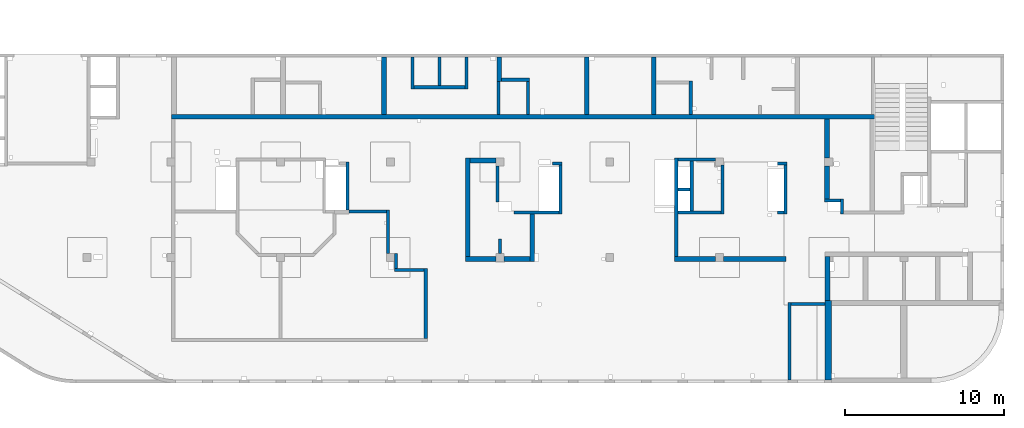
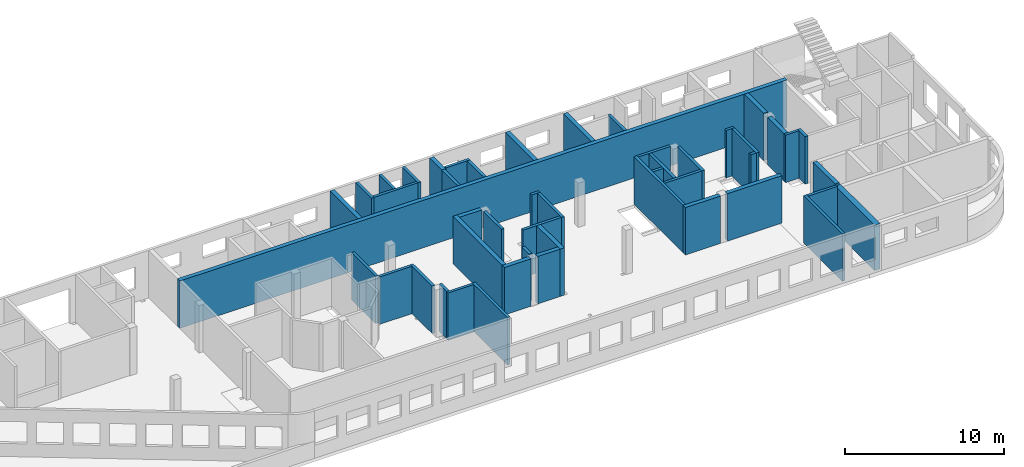
# One storey, part 4 of 10: 48 walls.
"""IFC4 building model written with IfcOpenShell, lengths in millimetres."""

from ifc_helpers import new_model, entity, si_unit, converted_unit, derived_unit, direction, frame, origin, place, context, subcontext, project, spatial, indexed_curve, outline, extrude, material, type_object, element, save


model = new_model("IFC4")

# Units and contexts
model_context = context("Model", 3, precision=0.01, world=origin(), true_north=direction((6.12303176911189e-17, 1.0)))
plan_context = context("Plan", 3, precision=0.01, world=origin(), true_north=direction((6.12303176911189e-17, 1.0)))
body_context = subcontext(model_context, "Body", "Model", "MODEL_VIEW")
ifc_project = project(units=[si_unit("LENGTHUNIT", "METRE", prefix="MILLI"), si_unit("AREAUNIT", "SQUARE_METRE"), si_unit("VOLUMEUNIT", "CUBIC_METRE"), converted_unit("PLANEANGLEUNIT", "DEGREE", entity("IfcRatioMeasure", 0.0174532925199433), si_unit("PLANEANGLEUNIT", "RADIAN"), dimensions=[0, 0, 0, 0, 0, 0, 0]), si_unit("MASSUNIT", "GRAM", prefix="KILO"), derived_unit("MASSDENSITYUNIT", [(si_unit("MASSUNIT", "GRAM", prefix="KILO"), 1), (si_unit("LENGTHUNIT", "METRE"), -3)]), derived_unit("MOMENTOFINERTIAUNIT", [(si_unit("LENGTHUNIT", "METRE"), 4)]), si_unit("TIMEUNIT", "SECOND"), si_unit("FREQUENCYUNIT", "HERTZ"), si_unit("THERMODYNAMICTEMPERATUREUNIT", "DEGREE_CELSIUS"), derived_unit("THERMALTRANSMITTANCEUNIT", [(si_unit("MASSUNIT", "GRAM", prefix="KILO"), 1), (si_unit("THERMODYNAMICTEMPERATUREUNIT", "KELVIN"), -1), (si_unit("TIMEUNIT", "SECOND"), -3)]), derived_unit("VOLUMETRICFLOWRATEUNIT", [(si_unit("LENGTHUNIT", "METRE"), 3), (si_unit("TIMEUNIT", "SECOND"), -1)]), derived_unit("MASSFLOWRATEUNIT", [(si_unit("MASSUNIT", "GRAM", prefix="KILO"), 1), (si_unit("TIMEUNIT", "SECOND"), -1)]), derived_unit("ROTATIONALFREQUENCYUNIT", [(si_unit("TIMEUNIT", "SECOND"), -1)]), si_unit("ELECTRICCURRENTUNIT", "AMPERE"), si_unit("ELECTRICVOLTAGEUNIT", "VOLT"), si_unit("POWERUNIT", "WATT"), si_unit("FORCEUNIT", "NEWTON", prefix="KILO"), si_unit("ILLUMINANCEUNIT", "LUX"), si_unit("LUMINOUSFLUXUNIT", "LUMEN"), si_unit("LUMINOUSINTENSITYUNIT", "CANDELA"), derived_unit("USERDEFINED", [(si_unit("MASSUNIT", "GRAM", prefix="KILO"), -1), (si_unit("LENGTHUNIT", "METRE"), -2), (si_unit("TIMEUNIT", "SECOND"), 3), (si_unit("LUMINOUSFLUXUNIT", "LUMEN"), 1)]), derived_unit("LINEARVELOCITYUNIT", [(si_unit("LENGTHUNIT", "METRE"), 1), (si_unit("TIMEUNIT", "SECOND"), -1)]), si_unit("PRESSUREUNIT", "PASCAL"), derived_unit("USERDEFINED", [(si_unit("LENGTHUNIT", "METRE"), -2), (si_unit("MASSUNIT", "GRAM", prefix="KILO"), 1), (si_unit("TIMEUNIT", "SECOND"), -2)]), derived_unit("LINEARFORCEUNIT", [(si_unit("MASSUNIT", "GRAM", prefix="KILO"), 1), (si_unit("LENGTHUNIT", "METRE"), 1), (si_unit("TIMEUNIT", "SECOND"), -2), (si_unit("LENGTHUNIT", "METRE"), -1)]), derived_unit("PLANARFORCEUNIT", [(si_unit("MASSUNIT", "GRAM", prefix="KILO"), 1), (si_unit("LENGTHUNIT", "METRE"), 1), (si_unit("TIMEUNIT", "SECOND"), -2), (si_unit("LENGTHUNIT", "METRE"), -2)])], contexts=[model_context, plan_context])

# Site, building, storey
site_placement = place(None, origin())
site = spatial("IfcSite", under=ifc_project, at=site_placement, CompositionType="ELEMENT")
building_placement = place(site_placement, origin())
building = spatial("IfcBuilding", under=site, at=building_placement, CompositionType="ELEMENT")
storey_placement = place(building_placement, frame((0.0, 0.0, 4200.0)))
storey = spatial("IfcBuildingStorey", under=building, at=storey_placement, Name="02", CompositionType="ELEMENT", Elevation=4200.0)

# Walls
ifc_material = material()
wall_type_1 = type_object("IfcWallType", Name=":ADSK_ 25_200", PredefinedType="STANDARD")
wall_1_placement = place(storey_placement, frame((36370.0, 20300.0, -150.0), z_axis=(0.0, 0.0, 1.0), x_axis=(0.0, -1.0, 0.0)))
element("IfcWall", 1, at=wall_1_placement, inside=storey, type_object=wall_type_1, material=ifc_material, Name=":ADSK_ 25_200", ObjectType=":ADSK_ 25_200", PredefinedType="NOTDEFINED", context=body_context, shape_type="SweptSolid", body=[
    extrude(outline(indexed_curve([(2000.00000000011, 99.9999999999993), (-2.37709667564423e-13, 99.9999999999989), (2.37709667564423e-13, -99.9999999999989), (2000.00000000011, -99.9999999999985), (2000.00000000011, 99.9999999999993)], self_intersect=False)), origin(), (0.0, 0.0, 1.0), 3600.0),
])
wall_2_placement = place(storey_placement, frame((38070.0, 20300.0, -150.0), z_axis=(0.0, 0.0, 1.0), x_axis=(0.0, -1.0, 0.0)))
element("IfcWall", 2, at=wall_2_placement, inside=storey, type_object=wall_type_1, material=ifc_material, Name=":ADSK_ 25_200", ObjectType=":ADSK_ 25_200", PredefinedType="NOTDEFINED", context=body_context, shape_type="SweptSolid", body=[
    extrude(outline(indexed_curve([(1800.00000000011, 99.9999999999989), (-2.37709667564423e-13, 99.9999999999989), (2.37709667564423e-13, -99.9999999999989), (1800.00000000011, -99.999999999999), (1800.00000000011, 99.9999999999989)], self_intersect=False)), origin(), (0.0, 0.0, 1.0), 3600.0),
])
wall_3_placement = place(storey_placement, frame((39770.0, 20300.0, -150.0), z_axis=(0.0, 0.0, 1.0), x_axis=(0.0, -1.0, 0.0)))
element("IfcWall", 3, at=wall_3_placement, inside=storey, type_object=wall_type_1, material=ifc_material, Name=":ADSK_ 25_200", ObjectType=":ADSK_ 25_200", PredefinedType="NOTDEFINED", context=body_context, shape_type="SweptSolid", body=[
    extrude(outline(indexed_curve([(2000.00000000011, 99.9999999999993), (-2.37709667564433e-13, 100.000000000003), (2.37709667564433e-13, -100.000000000003), (2000.00000000011, -100.000000000007), (2000.00000000011, 99.9999999999993)], self_intersect=False)), origin(), (0.0, 0.0, 1.0), 3600.0),
])
wall_4_placement = place(storey_placement, frame((36470.0, 18400.0, -150.0)))
element("IfcWall", 4, at=wall_4_placement, inside=storey, type_object=wall_type_1, material=ifc_material, Name=":ADSK_ 25_200", ObjectType=":ADSK_ 25_200", PredefinedType="NOTDEFINED", context=body_context, shape_type="SweptSolid", body=[
    extrude(outline(indexed_curve([(3200.00000000001, 99.9999999999986), (-3.28141554332843e-13, 99.9999999999989), (3.28141554332843e-13, -99.9999999999989), (3200.00000000001, -99.9999999999992), (3200.00000000001, 99.9999999999986)], self_intersect=False)), origin(), (0.0, 0.0, 1.0), 3600.0),
])
wall_5_placement = place(storey_placement, frame((41970.0, 18880.0, -150.0)))
element("IfcWall", 5, at=wall_5_placement, inside=storey, type_object=wall_type_1, material=ifc_material, Name=":ADSK_ 25_200", ObjectType=":ADSK_ 25_200", PredefinedType="NOTDEFINED", context=body_context, shape_type="SweptSolid", body=[
    extrude(outline(indexed_curve([(1749.99999999999, 99.9999999999981), (-3.22176291013974e-13, 99.9999999999989), (3.22176291013974e-13, -99.9999999999989), (1749.99999999999, -99.9999999999998), (1749.99999999999, 99.9999999999981)], self_intersect=False)), origin(), (0.0, 0.0, 1.0), 3650.0),
])
wall_6_placement = place(storey_placement, frame((41770.0, 18780.0, -150.0), z_axis=(0.0, 0.0, 1.0), x_axis=(0.0, -1.0, 0.0)))
element("IfcWall", 6, at=wall_6_placement, inside=storey, type_object=wall_type_1, material=ifc_material, Name=":ADSK_ 25_200", ObjectType=":ADSK_ 25_200", PredefinedType="NOTDEFINED", context=body_context, shape_type="SweptSolid", body=[
    extrude(outline(indexed_curve([(2080.0, 100.000000000003), (0.0, 100.000000000003), (0.0, -100.000000000003), (2080.0, -100.000000000003), (2080.0, 100.000000000003)], self_intersect=False)), origin(), (0.0, 0.0, 1.0), 3600.0),
])
wall_7_placement = place(storey_placement, frame((43620.0, 16700.0, -150.0), z_axis=(0.0, 0.0, 1.0), x_axis=(0.0, 1.0, 0.0)))
element("IfcWall", 7, at=wall_7_placement, inside=storey, type_object=wall_type_1, material=ifc_material, Name=":ADSK_ 25_200", ObjectType=":ADSK_ 25_200", PredefinedType="NOTDEFINED", context=body_context, shape_type="SweptSolid", body=[
    extrude(outline(indexed_curve([(2080.0, 100.000000000003), (0.0, 100.000000000003), (0.0, -100.000000000003), (2080.0, -100.000000000003), (2080.0, 100.000000000003)], self_intersect=False)), origin(), (0.0, 0.0, 1.0), 3650.0),
])
wall_8_placement = place(storey_placement, frame((53870.0, 16700.0, -150.0), z_axis=(0.0, 0.0, 1.0), x_axis=(0.0, 1.0, 0.0)))
element("IfcWall", 8, at=wall_8_placement, inside=storey, type_object=wall_type_1, material=ifc_material, Name=":ADSK_ 25_200", ObjectType=":ADSK_ 25_200", PredefinedType="NOTDEFINED", context=body_context, shape_type="SweptSolid", body=[
    extrude(outline(indexed_curve([(2100.0, 100.000000000003), (0.0, 100.000000000003), (0.0, -100.000000000003), (2100.0, -100.000000000003), (2100.0, 100.000000000003)], self_intersect=False)), origin(), (0.0, 0.0, 1.0), 3600.0),
])
wall_9_placement = place(storey_placement, frame((62295.0, 11285.0, -150.0)))
element("IfcWall", 9, at=wall_9_placement, inside=storey, type_object=wall_type_1, material=ifc_material, Name=":ADSK_ 25_200", ObjectType=":ADSK_ 25_200", PredefinedType="NOTDEFINED", context=body_context, shape_type="SweptSolid", body=[
    extrude(outline(indexed_curve([(990.0, 99.9999999999984), (-3.8634469513083e-13, 99.9999999999989), (3.8634469513083e-13, -99.9999999999989), (990.000000000001, -99.9999999999994), (990.0, 99.9999999999984)], self_intersect=False)), origin(), (0.0, 0.0, 1.0), 3650.0),
])
wall_10_placement = place(storey_placement, frame((63385.0, 11385.0, -150.0), z_axis=(0.0, 0.0, 1.0), x_axis=(0.0, -1.0, 0.0)))
element("IfcWall", 10, at=wall_10_placement, inside=storey, type_object=wall_type_1, material=ifc_material, Name=":ADSK_ 25_200", ObjectType=":ADSK_ 25_200", PredefinedType="NOTDEFINED", context=body_context, shape_type="SweptSolid", body=[
    extrude(outline(indexed_curve([(960.0, 100.000000000003), (0.0, 100.000000000003), (0.0, -100.000000000003), (960.0, -100.000000000003), (960.0, 100.000000000003)], self_intersect=False)), origin(), (0.0, 0.0, 1.0), 3650.0),
])
wall_11_placement = place(storey_placement, frame((59330.0, 13600.0, -150.0)))
element("IfcWall", 11, at=wall_11_placement, inside=storey, type_object=wall_type_1, material=ifc_material, Name=":ADSK_ 25_200", ObjectType=":ADSK_ 25_200", PredefinedType="NOTDEFINED", context=body_context, shape_type="SweptSolid", body=[
    extrude(outline(indexed_curve([(600.000000000002, 99.9999999999989), (-3.60955709766126e-13, 99.9999999999989), (3.60955709766126e-13, -99.9999999999989), (600.000000000003, -99.9999999999989), (600.000000000002, 99.9999999999989)], self_intersect=False)), origin(), (0.0, 0.0, 1.0), 3650.0),
])
wall_12_placement = place(storey_placement, frame((59830.0, 13500.0, -150.0), z_axis=(0.0, 0.0, 1.0), x_axis=(0.0, -1.0, 0.0)))
element("IfcWall", 12, at=wall_12_placement, inside=storey, type_object=wall_type_1, material=ifc_material, Name=":ADSK_ 25_200", ObjectType=":ADSK_ 25_200", PredefinedType="NOTDEFINED", context=body_context, shape_type="SweptSolid", body=[
    extrude(outline(indexed_curve([(3075.00000000016, 100.000000000003), (-2.64517161355328e-13, 100.000000000003), (2.64517161355328e-13, -100.000000000003), (3075.00000000016, -100.000000000004), (3075.00000000016, 100.000000000003)], self_intersect=False)), origin(), (0.0, 0.0, 1.0), 3650.0),
])
wall_13_placement = place(storey_placement, frame((59730.0, 10525.0, -150.0), z_axis=(0.0, 0.0, 1.0), x_axis=(-1.0, 0.0, 0.0)))
element("IfcWall", 13, at=wall_13_placement, inside=storey, type_object=wall_type_1, material=ifc_material, Name=":ADSK_ 25_200", ObjectType=":ADSK_ 25_200", PredefinedType="NOTDEFINED", context=body_context, shape_type="SweptSolid", body=[
    extrude(outline(indexed_curve([(400.000000000013, 99.9999999999982), (-3.6095570976612e-13, 99.9999999999989), (3.6095570976612e-13, -99.9999999999989), (400.000000000013, -99.9999999999996), (400.000000000013, 99.9999999999982)], self_intersect=False)), origin(), (0.0, 0.0, 1.0), 3650.0),
])
wall_14_placement = place(storey_placement, frame((60070.0, 0.0, -150.0), z_axis=(0.0, 0.0, 1.0), x_axis=(0.0, 1.0, 0.0)))
element("IfcWall", 14, at=wall_14_placement, inside=storey, type_object=wall_type_1, material=ifc_material, Name=":ADSK_ 25_200", ObjectType=":ADSK_ 25_200", PredefinedType="NOTDEFINED", context=body_context, shape_type="SweptSolid", body=[
    extrude(outline(indexed_curve([(4875.0, 100.000000000009), (-1.63282015819024e-14, 100.000000000003), (1.63282015819024e-14, -100.000000000003), (4875.0, -99.9999999999979), (4875.0, 100.000000000009)], self_intersect=False)), origin(), (0.0, 0.0, 1.0), 3650.0),
])
wall_15_placement = place(storey_placement, frame((62320.0, 4775.0, -150.0), z_axis=(0.0, 0.0, 1.0), x_axis=(-1.0, 0.0, 0.0)))
element("IfcWall", 15, at=wall_15_placement, inside=storey, type_object=wall_type_1, material=ifc_material, Name=":ADSK_ 25_200", ObjectType=":ADSK_ 25_200", PredefinedType="NOTDEFINED", context=body_context, shape_type="SweptSolid", body=[
    extrude(outline(indexed_curve([(2150.0, 99.9999999999995), (-3.2985095535215e-13, 100.0), (3.2985095535215e-13, -100.0), (2150.0, -100.000000000001), (2150.0, 99.9999999999995)], self_intersect=False)), origin(), (0.0, 0.0, 1.0), 3650.0),
])
wall_16_placement = place(storey_placement, frame((52950.0, 7750.0, -150.0), z_axis=(0.0, 0.0, 1.0), x_axis=(0.0, 1.0, 0.0)))
element("IfcWall", 16, at=wall_16_placement, inside=storey, type_object=wall_type_1, material=ifc_material, Name=":ADSK_ 25_200", ObjectType=":ADSK_ 25_200", PredefinedType="NOTDEFINED", context=body_context, shape_type="SweptSolid", body=[
    extrude(outline(indexed_curve([(6200.00000000002, 100.000000000003), (0.0, 100.000000000003), (0.0, -100.000000000003), (6200.00000000002, -100.000000000003), (6200.00000000002, 100.000000000003)], self_intersect=False)), origin(), (0.0, 0.0, 1.0), 3650.0),
])
wall_17_placement = place(storey_placement, frame((55870.0, 13500.0, -150.0), z_axis=(0.0, 0.0, 1.0), x_axis=(0.0, -1.0, 0.0)))
element("IfcWall", 17, at=wall_17_placement, inside=storey, type_object=wall_type_1, material=ifc_material, Name=":ADSK_ 25_200", ObjectType=":ADSK_ 25_200", PredefinedType="NOTDEFINED", context=body_context, shape_type="SweptSolid", body=[
    extrude(outline(indexed_curve([(3074.99999999999, 100.000000000003), (-2.72033140241541e-13, 100.000000000003), (2.72033140241541e-13, -100.000000000003), (3074.99999999999, -100.000000000004), (3074.99999999999, 100.000000000003)], self_intersect=False)), origin(), (0.0, 0.0, 1.0), 3650.0),
])
wall_18_placement = place(storey_placement, frame((55420.0, 13850.0, -150.0), z_axis=(0.0, 0.0, 1.0), x_axis=(-1.0, 0.0, 0.0)))
element("IfcWall", 18, at=wall_18_placement, inside=storey, type_object=wall_type_1, material=ifc_material, Name=":ADSK_ 25_200", ObjectType=":ADSK_ 25_200", PredefinedType="NOTDEFINED", context=body_context, shape_type="SweptSolid", body=[
    extrude(outline(indexed_curve([(2370.00000000002, 99.9999999999998), (-3.12103746660829e-13, 99.9999999999989), (3.12103746660829e-13, -99.9999999999989), (2370.00000000002, -99.999999999998), (2370.00000000002, 99.9999999999998)], self_intersect=False)), origin(), (0.0, 0.0, 1.0), 3650.0),
])
wall_19_placement = place(storey_placement, frame((55770.0, 10525.0, -150.0), z_axis=(0.0, 0.0, 1.0), x_axis=(-1.0, 0.0, 0.0)))
element("IfcWall", 19, at=wall_19_placement, inside=storey, type_object=wall_type_1, material=ifc_material, Name=":ADSK_ 25_200", ObjectType=":ADSK_ 25_200", PredefinedType="NOTDEFINED", context=body_context, shape_type="SweptSolid", body=[
    extrude(outline(indexed_curve([(2719.99999999999, 100.000000000001), (-3.01844495971679e-13, 100.000000000001), (3.01844495971679e-13, -100.000000000001), (2719.99999999999, -100.000000000002), (2719.99999999999, 100.000000000001)], self_intersect=False)), origin(), (0.0, 0.0, 1.0), 3650.0),
])
wall_20_placement = place(storey_placement, frame((53050.0, 11975.0, -150.0)))
element("IfcWall", 20, at=wall_20_placement, inside=storey, type_object=wall_type_1, material=ifc_material, Name=":ADSK_ 25_200", ObjectType=":ADSK_ 25_200", PredefinedType="NOTDEFINED", context=body_context, shape_type="SweptSolid", body=[
    extrude(outline(indexed_curve([(780.000000000004, 99.9999999999993), (-3.27472843447334e-13, 99.9999999999989), (3.27472843447334e-13, -99.9999999999989), (780.000000000005, -99.9999999999985), (780.000000000004, 99.9999999999993)], self_intersect=False)), origin(), (0.0, 0.0, 1.0), 3650.0),
])
wall_21_placement = place(storey_placement, frame((53930.0, 10625.0, -150.0), z_axis=(0.0, 0.0, 1.0), x_axis=(0.0, 1.0, 0.0)))
element("IfcWall", 21, at=wall_21_placement, inside=storey, type_object=wall_type_1, material=ifc_material, Name=":ADSK_ 25_200", ObjectType=":ADSK_ 25_200", PredefinedType="NOTDEFINED", context=body_context, shape_type="SweptSolid", body=[
    extrude(outline(indexed_curve([(3125.00000000001, 100.000000000003), (0.0, 100.000000000003), (0.0, -100.000000000003), (3125.00000000001, -100.000000000003), (3125.00000000001, 100.000000000003)], self_intersect=False)), origin(), (0.0, 0.0, 1.0), 3650.0),
])
wall_22_placement = place(storey_placement, frame((45170.0, 13600.0, -150.0)))
element("IfcWall", 22, at=wall_22_placement, inside=storey, type_object=wall_type_1, material=ifc_material, Name=":ADSK_ 25_200", ObjectType=":ADSK_ 25_200", PredefinedType="NOTDEFINED", context=body_context, shape_type="SweptSolid", body=[
    extrude(outline(indexed_curve([(600.000000000002, 99.9999999999989), (-3.60955709766126e-13, 99.9999999999989), (3.60955709766126e-13, -99.9999999999989), (600.000000000003, -99.9999999999989), (600.000000000002, 99.9999999999989)], self_intersect=False)), origin(), (0.0, 0.0, 1.0), 3650.0),
])
wall_23_placement = place(storey_placement, frame((45670.0, 13500.0, -150.0), z_axis=(0.0, 0.0, 1.0), x_axis=(0.0, -1.0, 0.0)))
element("IfcWall", 23, at=wall_23_placement, inside=storey, type_object=wall_type_1, material=ifc_material, Name=":ADSK_ 25_200", ObjectType=":ADSK_ 25_200", PredefinedType="NOTDEFINED", context=body_context, shape_type="SweptSolid", body=[
    extrude(outline(indexed_curve([(3075.0, 100.000000000003), (-2.64517161355341e-13, 100.000000000003), (2.64517161355341e-13, -100.000000000003), (3075.0, -100.000000000004), (3075.0, 100.000000000003)], self_intersect=False)), origin(), (0.0, 0.0, 1.0), 3650.0),
])
wall_24_placement = place(storey_placement, frame((45570.0, 10525.0, -150.0), z_axis=(0.0, 0.0, 1.0), x_axis=(-1.0, 0.0, 0.0)))
element("IfcWall", 24, at=wall_24_placement, inside=storey, type_object=wall_type_1, material=ifc_material, Name=":ADSK_ 25_200", ObjectType=":ADSK_ 25_200", PredefinedType="NOTDEFINED", context=body_context, shape_type="SweptSolid", body=[
    extrude(outline(indexed_curve([(2825.0, 99.9999999999986), (-2.21173189477145e-12, 99.9999999999989), (2.21173189477145e-12, -99.9999999999989), (2825.0, -99.9999999999992), (2825.0, 99.9999999999986)], self_intersect=False)), origin(), (0.0, 0.0, 1.0), 3650.0),
])
wall_25_placement = place(storey_placement, frame((41720.0, 13450.0, -150.0), z_axis=(0.0, 0.0, 1.0), x_axis=(0.0, -1.0, 0.0)))
element("IfcWall", 25, at=wall_25_placement, inside=storey, type_object=wall_type_1, material=ifc_material, Name=":ADSK_ 25_200", ObjectType=":ADSK_ 25_200", PredefinedType="NOTDEFINED", context=body_context, shape_type="SweptSolid", body=[
    extrude(outline(indexed_curve([(2265.0000000001, 100.000000000003), (0.0, 100.000000000003), (0.0, -100.000000000003), (2265.0000000001, -100.000000000003), (2265.0000000001, 100.000000000003)], self_intersect=False)), origin(), (0.0, 0.0, 1.0), 3650.0),
])
wall_26_placement = place(storey_placement, frame((37195.0, 2600.0, -150.0), z_axis=(0.0, 0.0, 1.0), x_axis=(0.0, 1.0, 0.0)))
element("IfcWall", 26, at=wall_26_placement, inside=storey, type_object=wall_type_1, material=ifc_material, Name=":ADSK_ 25_200", ObjectType=":ADSK_ 25_200", PredefinedType="NOTDEFINED", context=body_context, shape_type="SweptSolid", body=[
    extrude(outline(indexed_curve([(4400.0, 100.0), (-2.32366515949559e-13, 99.9999999999989), (2.32366515949559e-13, -99.9999999999989), (4400.0, -99.9999999999974), (4400.0, 100.0)], self_intersect=False)), origin(), (0.0, 0.0, 1.0), 3650.0),
])
wall_27_placement = place(storey_placement, frame((37095.0, 6900.0, -150.0), z_axis=(0.0, 0.0, 1.0), x_axis=(-1.0, 0.0, 0.0)))
element("IfcWall", 27, at=wall_27_placement, inside=storey, type_object=wall_type_1, material=ifc_material, Name=":ADSK_ 25_200", ObjectType=":ADSK_ 25_200", PredefinedType="NOTDEFINED", context=body_context, shape_type="SweptSolid", body=[
    extrude(outline(indexed_curve([(1875.00000000001, 100.0), (0.0, 100.0), (0.0, -100.0), (1875.00000000001, -100.0), (1875.00000000001, 100.0)], self_intersect=False)), origin(), (0.0, 0.0, 1.0), 3650.0),
])
wall_28_placement = place(storey_placement, frame((35320.0, 7000.0, -150.0), z_axis=(0.0, 0.0, 1.0), x_axis=(0.0, 1.0, 0.0)))
element("IfcWall", 28, at=wall_28_placement, inside=storey, type_object=wall_type_1, material=ifc_material, Name=":ADSK_ 25_200", ObjectType=":ADSK_ 25_200", PredefinedType="NOTDEFINED", context=body_context, shape_type="SweptSolid", body=[
    extrude(outline(indexed_curve([(950.000000000075, 99.9999999999989), (0.0, 99.9999999999989), (0.0, -99.9999999999989), (950.000000000075, -99.9999999999989), (950.000000000075, 99.9999999999989)], self_intersect=False)), origin(), (0.0, 0.0, 1.0), 3650.0),
])
wall_29_placement = place(storey_placement, frame((34820.0, 7950.0, -150.0), z_axis=(0.0, 0.0, 1.0), x_axis=(0.0, 1.0, 0.0)))
element("IfcWall", 29, at=wall_29_placement, inside=storey, type_object=wall_type_1, material=ifc_material, Name=":ADSK_ 25_200", ObjectType=":ADSK_ 25_200", PredefinedType="NOTDEFINED", context=body_context, shape_type="SweptSolid", body=[
    extrude(outline(indexed_curve([(2740.0, 99.999999999999), (-1.61924056717522e-13, 99.9999999999989), (1.61924056717522e-13, -99.9999999999989), (2740.0, -99.9999999999988), (2740.0, 99.999999999999)], self_intersect=False)), origin(), (0.0, 0.0, 1.0), 3650.0),
])
wall_30_placement = place(storey_placement, frame((34720.0, 10590.0, -150.0), z_axis=(0.0, 0.0, 1.0), x_axis=(-1.0, 0.0, 0.0)))
element("IfcWall", 30, at=wall_30_placement, inside=storey, type_object=wall_type_1, material=ifc_material, Name=":ADSK_ 25_200", ObjectType=":ADSK_ 25_200", PredefinedType="NOTDEFINED", context=body_context, shape_type="SweptSolid", body=[
    extrude(outline(indexed_curve([(2349.99999999999, 100.000000000002), (-5.70598363989661e-13, 100.000000000001), (5.70598363989661e-13, -100.000000000001), (2349.99999999999, -100.000000000001), (2349.99999999999, 100.000000000002)], self_intersect=False)), origin(), (0.0, 0.0, 1.0), 3650.0),
])
wall_31_placement = place(storey_placement, frame((32270.0, 10690.0, -150.0), z_axis=(0.0, 0.0, 1.0), x_axis=(0.0, 1.0, 0.0)))
element("IfcWall", 31, at=wall_31_placement, inside=storey, type_object=wall_type_1, material=ifc_material, Name=":ADSK_ 25_200", ObjectType=":ADSK_ 25_200", PredefinedType="NOTDEFINED", context=body_context, shape_type="SweptSolid", body=[
    extrude(outline(indexed_curve([(3009.99999999989, 99.9999999999989), (-1.43902608544639e-13, 99.9999999999989), (1.43902608544639e-13, -99.9999999999989), (3009.99999999989, -99.9999999999989), (3009.99999999989, 99.9999999999989)], self_intersect=False)), origin(), (0.0, 0.0, 1.0), 3650.0),
])
wall_32_placement = place(storey_placement, frame((41870.0, 7950.0, -150.0), z_axis=(0.0, 0.0, 1.0), x_axis=(0.0, 1.0, 0.0)))
element("IfcWall", 32, at=wall_32_placement, inside=storey, type_object=wall_type_1, material=ifc_material, Name=":ADSK_ 25_200", ObjectType=":ADSK_ 25_200", PredefinedType="NOTDEFINED", context=body_context, shape_type="SweptSolid", body=[
    extrude(outline(indexed_curve([(900.00077364374, 100.000000000003), (0.0, 100.000000000003), (0.0, -100.000000000003), (900.00077364374, -100.000000000003), (900.00077364374, 100.000000000003)], self_intersect=False)), origin(), (0.0, 0.0, 1.0), 3650.0),
])
wall_type_2 = type_object("IfcWallType", Name=":ADSK_ 25_300", PredefinedType="STANDARD")
wall_33_placement = place(storey_placement, frame((21220.0, 16550.0, -150.0)))
element("IfcWall", 33, at=wall_33_placement, inside=storey, type_object=wall_type_2, material=ifc_material, Name=":ADSK_ 25_300", ObjectType=":ADSK_ 25_300", PredefinedType="NOTDEFINED", context=body_context, shape_type="SweptSolid", body=[
    extrude(outline(indexed_curve([(44210.0, 150.000000000002), (-5.2028848286608e-13, 150.000000000001), (5.2028848286608e-13, -150.000000000001), (44210.0, -149.999999999999), (44210.0, 150.000000000002)], self_intersect=False)), origin(), (0.0, 0.0, 1.0), 3650.0),
])
wall_34_placement = place(storey_placement, frame((34570.0, 20300.0, -150.0), z_axis=(0.0, 0.0, 1.0), x_axis=(0.0, -1.0, 0.0)))
element("IfcWall", 34, at=wall_34_placement, inside=storey, type_object=wall_type_2, material=ifc_material, Name=":ADSK_ 25_300", ObjectType=":ADSK_ 25_300", PredefinedType="NOTDEFINED", context=body_context, shape_type="SweptSolid", body=[
    extrude(outline(indexed_curve([(3600.00000000024, 150.000000000001), (-1.806020255871e-13, 150.000000000001), (1.806020255871e-13, -150.000000000001), (3600.00000000024, -150.000000000001), (3600.00000000024, 150.000000000001)], self_intersect=False)), origin(), (0.0, 0.0, 1.0), 3600.0),
])
wall_35_placement = place(storey_placement, frame((41820.0, 20300.0, -150.0), z_axis=(0.0, 0.0, 1.0), x_axis=(0.0, -1.0, 0.0)))
element("IfcWall", 35, at=wall_35_placement, inside=storey, type_object=wall_type_2, material=ifc_material, Name=":ADSK_ 25_300", ObjectType=":ADSK_ 25_300", PredefinedType="NOTDEFINED", context=body_context, shape_type="SweptSolid", body=[
    extrude(outline(indexed_curve([(1520.00000000024, 150.000000000001), (0.0, 150.000000000001), (0.0, -150.000000000001), (1520.00000000024, -150.000000000001), (1520.00000000024, 150.000000000001)], self_intersect=False)), origin(), (0.0, 0.0, 1.0), 3600.0),
])
wall_36_placement = place(storey_placement, frame((47320.0, 20300.0, -150.0), z_axis=(0.0, 0.0, 1.0), x_axis=(0.0, -1.0, 0.0)))
element("IfcWall", 36, at=wall_36_placement, inside=storey, type_object=wall_type_2, material=ifc_material, Name=":ADSK_ 25_300", ObjectType=":ADSK_ 25_300", PredefinedType="NOTDEFINED", context=body_context, shape_type="SweptSolid", body=[
    extrude(outline(indexed_curve([(3600.00000000024, 150.000000000001), (-3.60955709766122e-13, 150.000000000001), (3.60955709766122e-13, -150.000000000001), (3600.00000000024, -150.000000000001), (3600.00000000024, 150.000000000001)], self_intersect=False)), origin(), (0.0, 0.0, 1.0), 3650.0),
])
wall_37_placement = place(storey_placement, frame((51540.0, 20300.0, -150.0), z_axis=(0.0, 0.0, 1.0), x_axis=(0.0, -1.0, 0.0)))
element("IfcWall", 37, at=wall_37_placement, inside=storey, type_object=wall_type_2, material=ifc_material, Name=":ADSK_ 25_300", ObjectType=":ADSK_ 25_300", PredefinedType="NOTDEFINED", context=body_context, shape_type="SweptSolid", body=[
    extrude(outline(indexed_curve([(3600.00000000024, 150.000000000001), (-3.60955709766122e-13, 150.000000000001), (3.60955709766122e-13, -150.000000000001), (3600.00000000024, -150.000000000001), (3600.00000000024, 150.000000000001)], self_intersect=False)), origin(), (0.0, 0.0, 1.0), 3600.0),
])
wall_38_placement = place(storey_placement, frame((62445.0, 13450.0, -150.0), z_axis=(0.0, 0.0, 1.0), x_axis=(0.0, -1.0, 0.0)))
element("IfcWall", 38, at=wall_38_placement, inside=storey, type_object=wall_type_2, material=ifc_material, Name=":ADSK_ 25_300", ObjectType=":ADSK_ 25_300", PredefinedType="NOTDEFINED", context=body_context, shape_type="SweptSolid", body=[
    extrude(outline(indexed_curve([(2064.99922635619, 149.999999999999), (1.01016495972246e-12, 150.000000000001), (-1.01016495972246e-12, -150.000000000001), (2064.99922635619, -150.000000000002), (2064.99922635619, 149.999999999999)], self_intersect=False)), origin(), (0.0, 0.0, 1.0), 3650.0),
])
wall_39_placement = place(storey_placement, frame((62445.0, 13950.0, -150.0), z_axis=(0.0, 0.0, 1.0), x_axis=(0.0, 1.0, 0.0)))
element("IfcWall", 39, at=wall_39_placement, inside=storey, type_object=wall_type_2, material=ifc_material, Name=":ADSK_ 25_300", ObjectType=":ADSK_ 25_300", PredefinedType="NOTDEFINED", context=body_context, shape_type="SweptSolid", body=[
    extrude(outline(indexed_curve([(2449.99999999978, 150.000000000001), (0.0, 150.000000000001), (0.0, -150.000000000001), (2449.99999999978, -150.000000000001), (2449.99999999978, 150.000000000001)], self_intersect=False)), origin(), (0.0, 0.0, 1.0), 3650.0),
])
wall_40_placement = place(storey_placement, frame((55420.0, 7600.0, -150.0), z_axis=(0.0, 0.0, 1.0), x_axis=(-1.0, 0.0, 0.0)))
element("IfcWall", 40, at=wall_40_placement, inside=storey, type_object=wall_type_2, material=ifc_material, Name=":ADSK_ 25_300", ObjectType=":ADSK_ 25_300", PredefinedType="NOTDEFINED", context=body_context, shape_type="SweptSolid", body=[
    extrude(outline(indexed_curve([(2570.0, 150.0), (-3.74838621680215e-13, 150.000000000001), (3.74838621680215e-13, -150.000000000001), (2570.00000000001, -150.000000000001), (2570.0, 150.0)], self_intersect=False)), origin(), (0.0, 0.0, 1.0), 3650.0),
])
wall_41_placement = place(storey_placement, frame((55920.0, 7600.0, -150.0)))
element("IfcWall", 41, at=wall_41_placement, inside=storey, type_object=wall_type_2, material=ifc_material, Name=":ADSK_ 25_300", ObjectType=":ADSK_ 25_300", PredefinedType="NOTDEFINED", context=body_context, shape_type="SweptSolid", body=[
    extrude(outline(indexed_curve([(3949.99999999999, 150.0), (-4.8342864025165e-13, 150.000000000001), (4.8342864025165e-13, -150.000000000001), (3949.99999999999, -150.000000000001), (3949.99999999999, 150.0)], self_intersect=False)), origin(), (0.0, 0.0, 1.0), 3650.0),
])
wall_42_placement = place(storey_placement, frame((43895.0, 10425.0, -150.0), z_axis=(0.0, 0.0, 1.0), x_axis=(0.0, -1.0, 0.0)))
element("IfcWall", 42, at=wall_42_placement, inside=storey, type_object=wall_type_2, material=ifc_material, Name=":ADSK_ 25_300", ObjectType=":ADSK_ 25_300", PredefinedType="NOTDEFINED", context=body_context, shape_type="SweptSolid", body=[
    extrude(outline(indexed_curve([(2975.00000000003, 150.000000000001), (7.74195519671281e-13, 150.000000000001), (-7.74195519671281e-13, -150.000000000001), (2975.00000000003, -150.0), (2975.00000000003, 150.000000000001)], self_intersect=False)), origin(), (0.0, 0.0, 1.0), 3650.0),
])
wall_43_placement = place(storey_placement, frame((42120.0, 7600.0, -150.0)))
element("IfcWall", 43, at=wall_43_placement, inside=storey, type_object=wall_type_2, material=ifc_material, Name=":ADSK_ 25_300", ObjectType=":ADSK_ 25_300", PredefinedType="NOTDEFINED", context=body_context, shape_type="SweptSolid", body=[
    extrude(outline(indexed_curve([(1624.9999999999, 150.0), (-4.19915577515643e-13, 150.000000000001), (4.19915577515643e-13, -150.000000000001), (1624.9999999999, -150.000000000001), (1624.9999999999, 150.0)], self_intersect=False)), origin(), (0.0, 0.0, 1.0), 3650.0),
])
wall_44_placement = place(storey_placement, frame((41620.0, 7600.0, -150.0), z_axis=(0.0, 0.0, 1.0), x_axis=(-1.0, 0.0, 0.0)))
element("IfcWall", 44, at=wall_44_placement, inside=storey, type_object=wall_type_2, material=ifc_material, Name=":ADSK_ 25_300", ObjectType=":ADSK_ 25_300", PredefinedType="NOTDEFINED", context=body_context, shape_type="SweptSolid", body=[
    extrude(outline(indexed_curve([(1925.0, 150.0), (3.18790998622199e-13, 150.000000000001), (-3.18790998622199e-13, -150.000000000001), (1925.0, -150.000000000001), (1925.0, 150.0)], self_intersect=False)), origin(), (0.0, 0.0, 1.0), 3650.0),
])
wall_45_placement = place(storey_placement, frame((39845.0, 7750.0, -150.0), z_axis=(0.0, 0.0, 1.0), x_axis=(0.0, 1.0, 0.0)))
element("IfcWall", 45, at=wall_45_placement, inside=storey, type_object=wall_type_2, material=ifc_material, Name=":ADSK_ 25_300", ObjectType=":ADSK_ 25_300", PredefinedType="NOTDEFINED", context=body_context, shape_type="SweptSolid", body=[
    extrude(outline(indexed_curve([(6200.00000000013, 150.000000000001), (0.0, 150.000000000001), (0.0, -150.000000000001), (6200.00000000013, -150.000000000001), (6200.00000000013, 150.000000000001)], self_intersect=False)), origin(), (0.0, 0.0, 1.0), 3650.0),
])
wall_46_placement = place(storey_placement, frame((41620.0, 13800.0, -150.0), z_axis=(0.0, 0.0, 1.0), x_axis=(-1.0, 0.0, 0.0)))
element("IfcWall", 46, at=wall_46_placement, inside=storey, type_object=wall_type_2, material=ifc_material, Name=":ADSK_ 25_300", ObjectType=":ADSK_ 25_300", PredefinedType="NOTDEFINED", context=body_context, shape_type="SweptSolid", body=[
    extrude(outline(indexed_curve([(1625.0, 150.000000000001), (-4.44253181250625e-13, 150.000000000001), (4.44253181250625e-13, -150.000000000001), (1625.0, -150.0), (1625.0, 150.000000000001)], self_intersect=False)), origin(), (0.0, 0.0, 1.0), 3650.0),
])
wall_47_placement = place(storey_placement, frame((62470.0, 4675.0, -150.0), z_axis=(0.0, 0.0, 1.0), x_axis=(0.0, 1.0, 0.0)))
element("IfcWall", 47, at=wall_47_placement, inside=storey, type_object=wall_type_2, material=ifc_material, Name=":ADSK_ 25_300", ObjectType=":ADSK_ 25_300", PredefinedType="NOTDEFINED", context=body_context, shape_type="SweptSolid", body=[
    extrude(outline(indexed_curve([(3074.99999999989, -150.000000000001), (3074.99999999989, 150.000000000001), (300.000000000001, 150.000000000001), (300.0, -150.000000000001), (2775.00000000007, -150.000000000001), (3074.99999999989, -150.000000000001)], self_intersect=False)), origin(), (0.0, 0.0, 1.0), 3650.0),
])
wall_type_3 = type_object("IfcWallType", Name=":ADSK_ 25_400", PredefinedType="STANDARD")
wall_48_placement = place(storey_placement, frame((62520.0, 0.0, -150.0), z_axis=(0.0, 0.0, 1.0), x_axis=(0.0, 1.0, 0.0)))
element("IfcWall", 48, at=wall_48_placement, inside=storey, type_object=wall_type_3, material=ifc_material, Name=":ADSK_ 25_400", ObjectType=":ADSK_ 25_400", PredefinedType="NOTDEFINED", context=body_context, shape_type="SweptSolid", body=[
    extrude(outline(indexed_curve([(4975.0, 199.999999999999), (-6.47205422223699e-15, 199.999999999998), (6.47205422223699e-15, -199.999999999998), (4975.0, -199.999999999997), (4975.0, 199.999999999999)], self_intersect=False)), origin(), (0.0, 0.0, 1.0), 3500.0),
])

save(model, "model.ifc")
